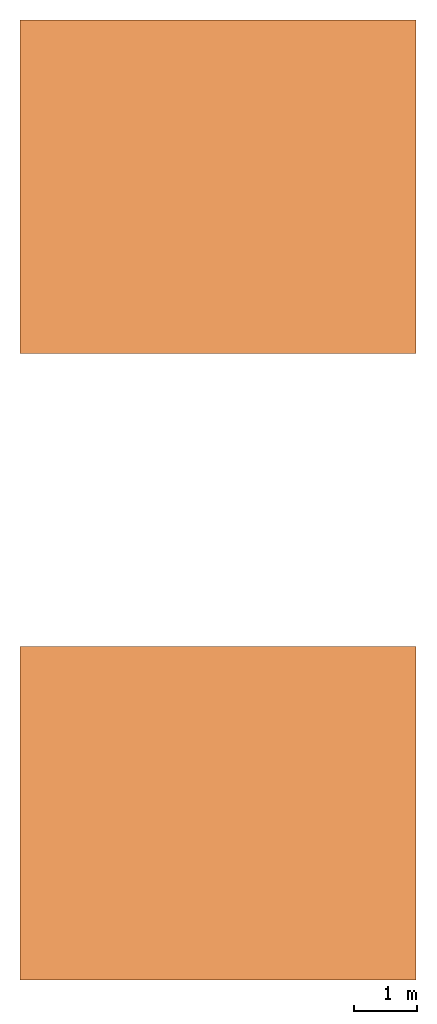
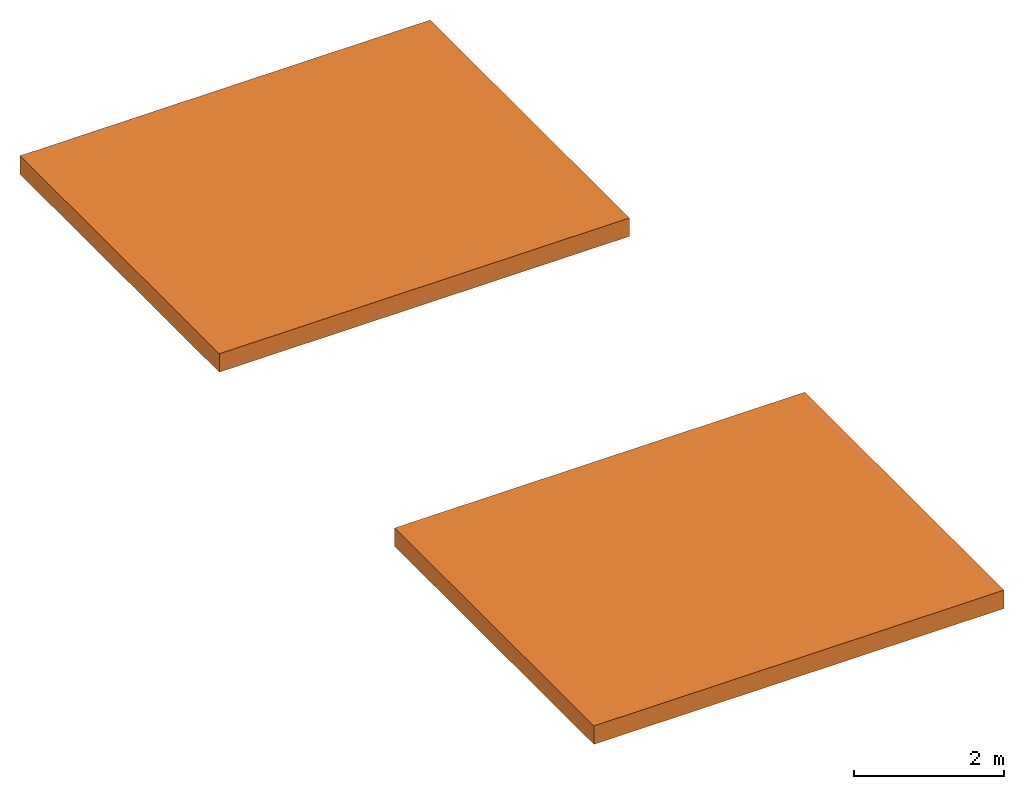
# One storey: 2 proxies.
"""IFC2X3 building model written with IfcOpenShell, lengths in metres."""

from ifc_helpers import new_model, entity, si_unit, converted_unit, derived_unit, money_unit, direction, frame, origin_with_axes, place, context, subcontext, project, spatial, polyline, outline, extrude, material, type_object, element, save


model = new_model("IFC2X3")

# Units and contexts
model_context = context("Model", 3, precision=1e-05, world=origin_with_axes(), true_north=direction((0.0, 1.0)))
body_context = subcontext(model_context, "Body", "Model", "MODEL_VIEW")
ifc_project = project(units=[si_unit("LENGTHUNIT", "METRE"), si_unit("AREAUNIT", "SQUARE_METRE"), si_unit("VOLUMEUNIT", "CUBIC_METRE"), converted_unit("PLANEANGLEUNIT", "DEGREE", entity("IfcPlaneAngleMeasure", 0.0174532925199433), si_unit("PLANEANGLEUNIT", "RADIAN"), dimensions=[0, 0, 0, 0, 0, 0, 0]), money_unit("EUR"), converted_unit("TIMEUNIT", "Year", entity("IfcTimeMeasure", 31557600.0), si_unit("TIMEUNIT", "SECOND"), dimensions=[0, 0, 1, 0, 0, 0, 0]), si_unit("MASSUNIT", "GRAM", prefix="KILO"), si_unit("THERMODYNAMICTEMPERATUREUNIT", "DEGREE_CELSIUS"), si_unit("LUMINOUSINTENSITYUNIT", "LUMEN"), si_unit("ENERGYUNIT", "JOULE", prefix="MEGA"), derived_unit("THERMALCONDUCTANCEUNIT", [(si_unit("POWERUNIT", "WATT"), 1), (si_unit("LENGTHUNIT", "METRE"), -1), (si_unit("THERMODYNAMICTEMPERATUREUNIT", "KELVIN"), -1)]), derived_unit("SPECIFICHEATCAPACITYUNIT", [(si_unit("ENERGYUNIT", "JOULE"), 1), (si_unit("MASSUNIT", "GRAM", prefix="KILO"), -1), (si_unit("THERMODYNAMICTEMPERATUREUNIT", "KELVIN"), -1)]), derived_unit("MASSDENSITYUNIT", [(si_unit("MASSUNIT", "GRAM", prefix="KILO"), 1), (si_unit("VOLUMEUNIT", "CUBIC_METRE"), -1)])], contexts=[model_context])

# Site, building, storey
site_placement = place(None, origin_with_axes())
site = spatial("IfcSite", under=ifc_project, at=site_placement, CompositionType="ELEMENT")
building_placement = place(site_placement, origin_with_axes())
building = spatial("IfcBuilding", under=site, at=building_placement, Name="Edificio", CompositionType="ELEMENT")
storey_placement = place(building_placement, frame((0.0, 0.0, 9.0), z_axis=(0.0, 0.0, 1.0), x_axis=(1.0, 0.0, 0.0)))
storey = spatial("IfcBuildingStorey", under=building, at=storey_placement, Name="L03", CompositionType="ELEMENT", Elevation=9.0)

# Proxies
ifc_material = material(Name="Cemento - Strutturale")
building_element_proxy_type = type_object("IfcBuildingElementProxyType", Name="Cemento - Strutturale 300", PredefinedType="NOTDEFINED")
for number, where, z_axis, x_axis, name in (
    (1, (-0.16, -0.16, 0.0), (0.0, 0.0, 1.0), (1.0, 0.0, 0.0), "SOL_003"),
    (2, (-0.1599999999999991, 9.84, 0.0), (0.0, 0.0, 1.0), (1.0, 0.0, 0.0), "SOL_007"),
):
    element("IfcBuildingElementProxy", number, at=place(storey_placement, frame(where, z_axis=z_axis, x_axis=x_axis)), inside=storey, type_object=building_element_proxy_type, material=ifc_material, Name=name, context=body_context, shape_type="SweptSolid", body=[
        extrude(outline(polyline([(0.0, 0.0), (6.32, 0.0), (6.32, 5.32), (0.0, 5.32), (0.0, 0.0)])), frame((0.0, 0.0, -0.3), z_axis=(0.0, 0.0, 1.0), x_axis=(1.0, 0.0, 0.0)), (0.0, 0.0, 1.0), 0.3),
    ])

save(model, "model.ifc")
